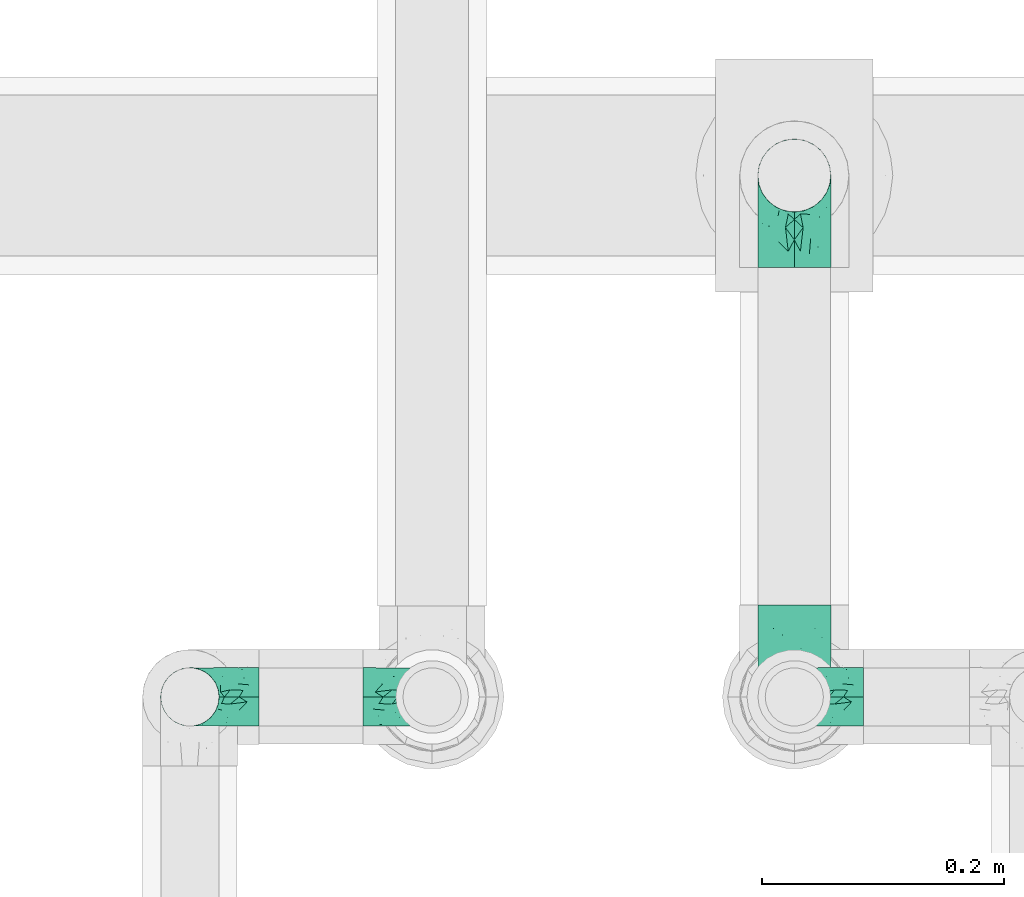
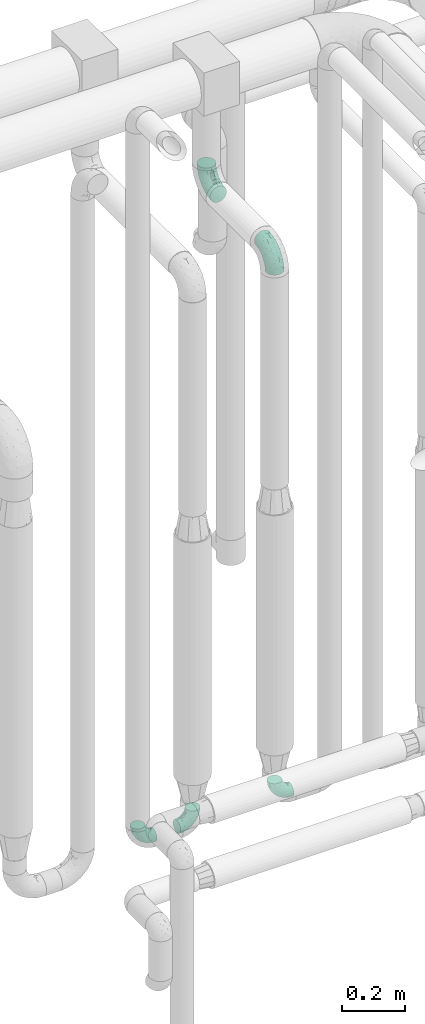
# One storey, part 716 of 827: 5 flow fittings.
"""IFC2X3 building model written with IfcOpenShell, lengths in millimetres."""

from ifc_helpers import new_model, entity, si_unit, converted_unit, derived_unit, direction, frame, origin, place, context, subcontext, project, spatial, faceted_brep, source, transform, mapped, material, type_object, type_shapes, element, save


model = new_model("IFC2X3")

# Units and contexts
model_context = context("Model", 3, precision=0.01, world=origin(), true_north=direction((6.12303176911189e-17, 1.0)))
body_context = subcontext(model_context, "Body", "Model", "MODEL_VIEW")
ifc_project = project(units=[si_unit("LENGTHUNIT", "METRE", prefix="MILLI"), si_unit("AREAUNIT", "SQUARE_METRE"), si_unit("VOLUMEUNIT", "CUBIC_METRE"), converted_unit("PLANEANGLEUNIT", "DEGREE", entity("IfcRatioMeasure", 0.0174532925199433), si_unit("PLANEANGLEUNIT", "RADIAN"), dimensions=[0, 0, 0, 0, 0, 0, 0]), si_unit("MASSUNIT", "GRAM", prefix="KILO"), derived_unit("MASSDENSITYUNIT", [(si_unit("MASSUNIT", "GRAM", prefix="KILO"), 1), (si_unit("LENGTHUNIT", "METRE"), -3)]), derived_unit("MOMENTOFINERTIAUNIT", [(si_unit("LENGTHUNIT", "METRE"), 4)]), si_unit("TIMEUNIT", "SECOND"), si_unit("FREQUENCYUNIT", "HERTZ"), si_unit("THERMODYNAMICTEMPERATUREUNIT", "DEGREE_CELSIUS"), derived_unit("THERMALTRANSMITTANCEUNIT", [(si_unit("MASSUNIT", "GRAM", prefix="KILO"), 1), (si_unit("THERMODYNAMICTEMPERATUREUNIT", "KELVIN"), -1), (si_unit("TIMEUNIT", "SECOND"), -3)]), derived_unit("VOLUMETRICFLOWRATEUNIT", [(si_unit("LENGTHUNIT", "METRE"), 3), (si_unit("TIMEUNIT", "SECOND"), -1)]), derived_unit("MASSFLOWRATEUNIT", [(si_unit("MASSUNIT", "GRAM", prefix="KILO"), 1), (si_unit("TIMEUNIT", "SECOND"), -1)]), derived_unit("ROTATIONALFREQUENCYUNIT", [(si_unit("TIMEUNIT", "SECOND"), -1)]), si_unit("ELECTRICCURRENTUNIT", "AMPERE"), si_unit("ELECTRICVOLTAGEUNIT", "VOLT"), si_unit("POWERUNIT", "WATT"), si_unit("FORCEUNIT", "NEWTON", prefix="KILO"), si_unit("ILLUMINANCEUNIT", "LUX"), si_unit("LUMINOUSFLUXUNIT", "LUMEN"), si_unit("LUMINOUSINTENSITYUNIT", "CANDELA"), derived_unit("USERDEFINED", [(si_unit("MASSUNIT", "GRAM", prefix="KILO"), -1), (si_unit("LENGTHUNIT", "METRE"), -2), (si_unit("TIMEUNIT", "SECOND"), 3), (si_unit("LUMINOUSFLUXUNIT", "LUMEN"), 1)]), derived_unit("LINEARVELOCITYUNIT", [(si_unit("LENGTHUNIT", "METRE"), 1), (si_unit("TIMEUNIT", "SECOND"), -1)]), si_unit("PRESSUREUNIT", "PASCAL"), derived_unit("USERDEFINED", [(si_unit("LENGTHUNIT", "METRE"), -2), (si_unit("MASSUNIT", "GRAM", prefix="KILO"), 1), (si_unit("TIMEUNIT", "SECOND"), -2)]), derived_unit("LINEARFORCEUNIT", [(si_unit("MASSUNIT", "GRAM", prefix="KILO"), 1), (si_unit("LENGTHUNIT", "METRE"), 1), (si_unit("TIMEUNIT", "SECOND"), -2), (si_unit("LENGTHUNIT", "METRE"), -1)]), derived_unit("PLANARFORCEUNIT", [(si_unit("MASSUNIT", "GRAM", prefix="KILO"), 1), (si_unit("LENGTHUNIT", "METRE"), 1), (si_unit("TIMEUNIT", "SECOND"), -2), (si_unit("LENGTHUNIT", "METRE"), -2)])], contexts=[model_context])

# Site, building, storey
site_placement = place(None, origin())
site = spatial("IfcSite", under=ifc_project, at=site_placement, CompositionType="ELEMENT")
building_placement = place(site_placement, origin())
building = spatial("IfcBuilding", under=site, at=building_placement, CompositionType="ELEMENT")
storey_placement = place(building_placement, frame((0.0, 0.0, 28200.0)))
storey = spatial("IfcBuildingStorey", under=building, at=storey_placement, Name="08", CompositionType="ELEMENT", Elevation=28200.0)

# Flow fittings
ifc_material = material()
pipe_fitting_type_1 = type_object("IfcPipeFittingType", Name="ADSK_1", PredefinedType="NOTDEFINED", material=ifc_material)
shared_shape_1 = source(origin(), body_context, "Body", "Brep", [
    faceted_brep([(-57.0, 12.07, -20.91), (-57.0, 6.25, -23.33), (-57.0, 0.0, -24.15), (-57.0, -6.25, -23.33), (-57.0, -12.08, -20.91), (-57.0, -17.08, -17.08), (-57.0, -20.91, -12.08), (-57.0, -23.33, -6.25), (-57.0, -24.15, 0.0), (-57.0, -23.33, 6.25), (-57.0, -20.91, 12.07), (-57.0, -17.08, 17.08), (-57.0, -12.08, 20.91), (-57.0, -6.25, 23.33), (-57.0, 0.0, 24.15), (-57.0, 6.25, 23.33), (-57.0, 12.07, 20.91), (-57.0, 17.08, 17.08), (-57.0, 20.91, 12.07), (-57.0, 23.33, 6.25), (-57.0, 24.15, 0.0), (-57.0, 23.33, -6.25), (-57.0, 20.91, -12.08), (-57.0, 17.08, -17.08), (0.0, 57.0, -24.15), (-6.25, 57.0, -23.33), (-12.07, 57.0, -20.91), (-17.08, 57.0, -17.08), (-20.91, 57.0, -12.08), (-23.33, 57.0, -6.25), (-24.15, 57.0, 0.0), (-23.33, 57.0, 6.25), (-20.91, 57.0, 12.07), (-17.08, 57.0, 17.08), (-12.07, 57.0, 20.91), (-6.25, 57.0, 23.33), (0.0, 57.0, 24.15), (6.25, 57.0, 23.33), (12.08, 57.0, 20.91), (17.08, 57.0, 17.08), (20.91, 57.0, 12.07), (23.33, 57.0, 6.25), (24.15, 57.0, 0.0), (23.33, 57.0, -6.25), (20.91, 57.0, -12.08), (17.08, 57.0, -17.08), (12.08, 57.0, -20.91), (6.25, 57.0, -23.33), (14.9, 21.14, 6.17), (13.61, 24.64, 12.48), (6.23, 8.95, 8.98), (-41.47, -21.06, 0.0), (-41.92, -18.38, 13.72), (-24.64, -13.61, 12.48), (-37.37, -13.24, 18.15), (-6.8, -4.93, 8.18), (-21.76, -15.19, 6.22), (-12.78, -9.18, 0.0), (-37.73, -20.51, 7.75), (-7.38, 7.38, 20.24), (-23.37, -4.26, 20.42), (-11.9, -3.19, 15.86), (-42.14, -8.7, 21.82), (13.24, 37.37, 18.15), (9.33, 23.53, 16.85), (4.26, 23.37, 20.42), (2.77, 10.92, 15.55), (-29.46, 0.91, 23.52), (-44.13, 20.56, 15.69), (-39.25, 26.33, 10.88), (-49.02, 22.92, 9.96), (-34.58, 23.87, 17.15), (-15.8, 6.8, 22.81), (-8.67, 20.47, 23.88), (-18.12, 12.9, 24.08), (-48.29, 14.92, 19.65), (-44.06, -2.85, 23.78), (-9.23, 48.95, 22.58), (-3.78, 42.74, 24.07), (-40.34, 4.26, 24.09), (-44.02, 26.14, 5.46), (-44.04, 9.88, 22.74), (-4.95, 16.87, 22.52), (-2.75, 1.43, 12.5), (-25.48, 40.98, 10.71), (20.51, 37.73, 7.75), (18.38, 41.92, 13.72), (8.7, 42.14, 21.82), (-25.95, -17.97, 0.0), (2.85, 44.06, 23.78), (21.06, 41.47, 0.0), (17.97, 25.95, 0.0), (-24.04, -9.27, 17.13), (-33.26, 33.26, 5.86), (-28.55, 40.57, 0.0), (-40.57, 28.55, 0.0), (-25.29, 47.19, 4.06), (-27.01, 31.1, 16.77), (-15.7, 43.95, 19.9), (-20.27, 45.22, 15.61), (-30.53, 31.98, 12.64), (-11.28, 38.33, 22.92), (-9.97, 27.88, 24.09), (-20.15, 30.26, 21.25), (-31.25, 11.75, 23.64), (-28.75, 7.23, 24.15), (-29.53, 18.06, 22.27), (-28.44, 24.21, 20.02), (-37.55, 17.7, 20.26), (-15.88, 29.25, 22.99), (-20.82, 20.82, 23.44), (-0.91, 29.46, 23.52), (-13.5, -7.67, 12.04), (1.49, 1.56, 5.16), (8.86, 10.35, 4.59), (0.38, -0.38, 0.0), (9.18, 12.78, 0.0), (-37.37, -13.24, -18.15), (8.86, 10.35, -4.59), (-45.22, 20.27, -15.61), (-43.95, 15.7, -19.9), (-38.33, 11.28, -22.92), (-48.95, 9.23, -22.58), (-47.19, 25.29, -4.06), (-33.26, 33.26, -5.86), (18.38, 41.92, -13.72), (-30.26, 20.15, -21.25), (2.85, 44.06, -23.78), (-4.26, 40.34, -24.09), (-40.98, 25.48, -10.71), (-41.92, -18.38, -13.72), (9.25, 23.5, -16.92), (4.26, 23.37, -20.42), (13.24, 37.37, -18.15), (-37.73, -20.51, -7.75), (-11.75, 31.25, -23.64), (-7.23, 28.75, -24.15), (-12.9, 18.12, -24.08), (8.7, 42.14, -21.82), (-44.06, -2.85, -23.78), (-6.8, 15.8, -22.81), (-20.47, 8.67, -23.88), (-24.64, -13.61, -12.48), (-42.74, 3.78, -24.07), (-18.06, 29.53, -22.27), (-24.21, 28.44, -20.02), (-27.88, 9.97, -24.09), (-31.1, 27.01, -16.77), (-26.14, 44.02, -5.46), (14.9, 21.14, -6.17), (20.51, 37.73, -7.75), (-9.88, 44.04, -22.74), (-20.56, 44.13, -15.69), (-21.76, -15.19, -6.22), (-13.5, -7.67, -12.04), (-24.14, -9.76, -16.74), (-11.9, -3.19, -15.86), (-14.92, 48.29, -19.65), (-23.37, -4.26, -20.42), (-0.91, 29.46, -23.52), (-26.33, 39.25, -10.88), (-23.87, 34.58, -17.15), (-42.14, -8.7, -21.82), (-22.92, 49.02, -9.96), (13.61, 24.64, -12.48), (-31.98, 30.53, -12.64), (-16.87, 4.95, -22.52), (-17.7, 37.55, -20.26), (-29.25, 15.88, -22.99), (-20.82, 20.82, -23.44), (-29.46, 0.91, -23.52), (-7.38, 7.38, -20.24), (2.77, 10.92, -15.55), (6.23, 8.95, -8.98), (-6.8, -4.93, -8.18), (-2.81, 1.41, -12.54), (1.49, 1.56, -5.16)], [[[0, 1, 2, 3, 4, 5, 6, 7, 8, 9, 10, 11, 12, 13, 14, 15, 16, 17, 18, 19, 20, 21, 22, 23]], [[24, 25, 26, 27, 28, 29, 30, 31, 32, 33, 34, 35, 36, 37, 38, 39, 40, 41, 42, 43, 44, 45, 46, 47]], [[48, 49, 50]], [[9, 8, 51]], [[52, 53, 54]], [[55, 56, 57]], [[10, 58, 52]], [[9, 58, 10]], [[59, 60, 61]], [[54, 12, 11]], [[54, 62, 12]], [[63, 39, 38]], [[64, 65, 66]], [[62, 60, 67]], [[68, 69, 70]], [[71, 69, 68]], [[72, 73, 74]], [[16, 75, 17]], [[13, 76, 14]], [[35, 77, 78]], [[14, 79, 15]], [[17, 68, 18]], [[14, 76, 79]], [[20, 19, 80]], [[70, 19, 18]], [[81, 15, 79]], [[15, 81, 16]], [[73, 72, 82]], [[66, 83, 50]], [[32, 31, 84]], [[85, 86, 49]], [[63, 87, 65]], [[56, 58, 88]], [[36, 89, 37]], [[85, 41, 40]], [[36, 35, 78]], [[90, 41, 85]], [[40, 39, 86]], [[12, 62, 13]], [[86, 85, 40]], [[48, 85, 49]], [[85, 91, 90]], [[87, 38, 37]], [[92, 60, 54]], [[80, 69, 93]], [[93, 94, 95]], [[10, 52, 11]], [[94, 96, 30]], [[97, 98, 99]], [[80, 93, 95]], [[100, 97, 84]], [[99, 98, 33]], [[101, 102, 78]], [[103, 101, 98]], [[96, 31, 30]], [[77, 98, 101]], [[77, 35, 34]], [[34, 33, 98]], [[9, 51, 58]], [[87, 63, 38]], [[104, 105, 74]], [[106, 103, 107]], [[106, 81, 104]], [[75, 68, 17]], [[108, 107, 71]], [[33, 32, 99]], [[109, 103, 110]], [[101, 109, 102]], [[89, 78, 111]], [[53, 52, 58]], [[54, 11, 52]], [[60, 62, 54]], [[88, 58, 51]], [[76, 62, 67]], [[53, 112, 92]], [[60, 59, 72]], [[39, 63, 86]], [[49, 86, 63]], [[89, 87, 37]], [[42, 41, 90]], [[111, 82, 65]], [[111, 65, 87]], [[65, 59, 66]], [[104, 81, 79]], [[75, 81, 108]], [[32, 84, 99]], [[97, 99, 84]], [[98, 97, 103]], [[106, 107, 108]], [[74, 102, 110]], [[111, 78, 102]], [[74, 110, 104]], [[74, 67, 72]], [[61, 92, 112]], [[66, 59, 61]], [[56, 53, 58]], [[66, 50, 49]], [[61, 112, 83]], [[66, 49, 64]], [[78, 89, 36]], [[87, 89, 111]], [[62, 76, 13]], [[79, 76, 67]], [[100, 93, 69]], [[96, 93, 84]], [[55, 113, 50]], [[113, 114, 50]], [[104, 79, 105]], [[106, 104, 110]], [[20, 80, 95]], [[85, 48, 91]], [[115, 114, 113]], [[116, 91, 48]], [[70, 80, 19]], [[93, 96, 94]], [[84, 31, 96]], [[103, 106, 110]], [[81, 106, 108]], [[103, 97, 107]], [[71, 107, 97]], [[71, 97, 100]], [[108, 71, 68]], [[79, 67, 105]], [[67, 74, 105]], [[115, 113, 57]], [[112, 56, 55]], [[56, 88, 57]], [[60, 72, 67]], [[82, 72, 59]], [[65, 82, 59]], [[82, 111, 73]], [[111, 102, 73]], [[102, 74, 73]], [[81, 75, 16]], [[68, 75, 108]], [[68, 70, 18]], [[80, 70, 69]], [[98, 77, 34]], [[78, 77, 101]], [[93, 100, 84]], [[71, 100, 69]], [[102, 109, 110]], [[101, 103, 109]], [[53, 92, 54]], [[61, 60, 92]], [[56, 112, 53]], [[83, 112, 55]], [[50, 83, 55]], [[61, 83, 66]], [[49, 63, 64]], [[65, 64, 63]], [[57, 113, 55]], [[114, 115, 116]], [[116, 48, 114]], [[48, 50, 114]], [[117, 5, 4]], [[116, 115, 118]], [[119, 120, 23]], [[121, 122, 120]], [[95, 123, 20]], [[0, 23, 120]], [[124, 95, 94]], [[125, 45, 44]], [[121, 120, 126]], [[24, 127, 128]], [[22, 21, 129]], [[0, 122, 1]], [[5, 117, 130]], [[131, 132, 133]], [[134, 88, 51]], [[135, 136, 137]], [[6, 5, 130]], [[46, 138, 47]], [[139, 3, 2]], [[140, 141, 137]], [[6, 134, 7]], [[134, 130, 142]], [[143, 2, 1]], [[144, 126, 145]], [[121, 146, 143]], [[147, 120, 119]], [[94, 148, 124]], [[149, 150, 91]], [[30, 29, 148]], [[151, 25, 128]], [[27, 152, 28]], [[134, 153, 88]], [[154, 155, 156]], [[27, 26, 157]], [[151, 26, 25]], [[155, 158, 156]], [[24, 47, 127]], [[1, 122, 143]], [[138, 132, 159]], [[160, 152, 161]], [[24, 128, 25]], [[46, 133, 138]], [[162, 117, 4]], [[148, 160, 124]], [[152, 160, 163]], [[154, 142, 155]], [[45, 125, 133]], [[133, 46, 45]], [[125, 164, 133]], [[51, 7, 134]], [[42, 90, 43]], [[165, 147, 129]], [[153, 134, 142]], [[43, 150, 44]], [[162, 4, 3]], [[141, 140, 166]], [[117, 162, 158]], [[163, 29, 28]], [[43, 90, 150]], [[123, 21, 20]], [[144, 151, 135]], [[157, 152, 27]], [[167, 145, 161]], [[23, 22, 119]], [[168, 126, 169]], [[121, 168, 146]], [[139, 143, 170]], [[142, 130, 117]], [[8, 7, 51]], [[134, 6, 130]], [[139, 162, 3]], [[170, 166, 158]], [[170, 158, 162]], [[158, 171, 156]], [[44, 150, 125]], [[91, 150, 90]], [[164, 125, 150]], [[132, 138, 133]], [[127, 138, 159]], [[131, 164, 172]], [[132, 171, 140]], [[135, 151, 128]], [[157, 151, 167]], [[22, 129, 119]], [[147, 119, 129]], [[120, 147, 126]], [[144, 145, 167]], [[137, 146, 169]], [[170, 143, 146]], [[137, 169, 135]], [[137, 159, 140]], [[171, 172, 156]], [[173, 174, 175]], [[156, 175, 154]], [[174, 57, 153]], [[132, 172, 171]], [[172, 164, 173]], [[143, 139, 2]], [[162, 139, 170]], [[138, 127, 47]], [[128, 127, 159]], [[165, 124, 160]], [[123, 124, 129]], [[149, 173, 164]], [[176, 174, 173]], [[135, 128, 136]], [[144, 135, 169]], [[150, 149, 164]], [[176, 118, 115]], [[149, 91, 116]], [[30, 148, 94]], [[163, 148, 29]], [[124, 123, 95]], [[129, 21, 123]], [[126, 144, 169]], [[151, 144, 167]], [[126, 147, 145]], [[161, 145, 147]], [[161, 147, 165]], [[167, 161, 152]], [[128, 159, 136]], [[159, 137, 136]], [[154, 153, 142]], [[132, 140, 159]], [[174, 176, 57]], [[57, 88, 153]], [[166, 140, 171]], [[158, 166, 171]], [[166, 170, 141]], [[170, 146, 141]], [[146, 137, 141]], [[151, 157, 26]], [[152, 157, 167]], [[152, 163, 28]], [[148, 163, 160]], [[120, 122, 0]], [[143, 122, 121]], [[124, 165, 129]], [[161, 165, 160]], [[146, 168, 169]], [[121, 126, 168]], [[142, 117, 155]], [[158, 155, 117]], [[175, 156, 172]], [[153, 154, 174]], [[173, 175, 172]], [[174, 154, 175]], [[164, 131, 133]], [[172, 132, 131]], [[176, 173, 118]], [[57, 176, 115]], [[173, 149, 118]], [[149, 116, 118]]]),
])
type_shapes(pipe_fitting_type_1, [shared_shape_1])
for number, where, z_axis, x_axis, name in (
    (1, (59098.13, 17500.0, 400.0), (0.0, -1.0, 0.0), (0.0, 0.0, -1.0), "ADSK_1"),
    (2, (59298.13, 17500.0, 400.0), (0.0, -1.0, 0.0), (1.0, 0.0, 0.0), "ADSK_1"),
    (3, (59596.67, 17500.0, 400.0), (0.0, 1.0, 0.0), (-1.0, 0.0, 0.0), "ADSK_1"),
):
    element("IfcFlowFitting", number, at=place(storey_placement, frame(where, z_axis=z_axis, x_axis=x_axis)), inside=storey, type_object=pipe_fitting_type_1, material=ifc_material, Name=name, ObjectType="ADSK_1", context=body_context, shape_type="MappedRepresentation", body=[
        mapped(shared_shape_1, transform((0.0, 0.0, 0.0), scale=1.0)),
    ])
pipe_fitting_type_2 = type_object("IfcPipeFittingType", Name="ADSK_1", PredefinedType="NOTDEFINED", material=ifc_material)
shared_shape_2 = source(origin(), body_context, "Body", "Brep", [
    faceted_brep([(-76.0, 15.07, -26.11), (-76.0, 7.8, -29.12), (-76.0, 0.0, -30.15), (-76.0, -7.8, -29.12), (-76.0, -15.08, -26.11), (-76.0, -21.32, -21.32), (-76.0, -26.11, -15.08), (-76.0, -29.12, -7.8), (-76.0, -30.15, 0.0), (-76.0, -29.12, 7.8), (-76.0, -26.11, 15.07), (-76.0, -21.32, 21.32), (-76.0, -15.08, 26.11), (-76.0, -7.8, 29.12), (-76.0, 0.0, 30.15), (-76.0, 7.8, 29.12), (-76.0, 15.07, 26.11), (-76.0, 21.32, 21.32), (-76.0, 26.11, 15.07), (-76.0, 29.12, 7.8), (-76.0, 30.15, 0.0), (-76.0, 29.12, -7.8), (-76.0, 26.11, -15.08), (-76.0, 21.32, -21.32), (0.0, 76.0, -30.15), (-7.8, 76.0, -29.12), (-15.07, 76.0, -26.11), (-21.32, 76.0, -21.32), (-26.11, 76.0, -15.08), (-29.12, 76.0, -7.8), (-30.15, 76.0, 0.0), (-29.12, 76.0, 7.8), (-26.11, 76.0, 15.07), (-21.32, 76.0, 21.32), (-15.07, 76.0, 26.11), (-7.8, 76.0, 29.12), (0.0, 76.0, 30.15), (7.8, 76.0, 29.12), (15.08, 76.0, 26.11), (21.32, 76.0, 21.32), (26.11, 76.0, 15.07), (29.12, 76.0, 7.8), (30.15, 76.0, 0.0), (29.12, 76.0, -7.8), (26.11, 76.0, -15.08), (21.32, 76.0, -21.32), (15.08, 76.0, -26.11), (7.8, 76.0, -29.12), (10.79, 31.43, 21.07), (4.32, 31.7, 25.72), (1.65, 15.19, 19.92), (-61.17, -27.8, 0.0), (-51.1, -25.49, 9.84), (-56.14, -10.61, 27.27), (-31.7, -4.32, 25.72), (-39.75, 1.72, 29.41), (-43.2, -24.95, 0.0), (-1.86, 1.86, 0.0), (4.49, 7.65, 5.78), (-7.82, -4.61, 5.83), (-56.21, -22.79, 17.21), (-58.98, -3.38, 29.7), (-53.96, 5.6, 30.07), (-10.86, 10.86, 25.48), (-17.2, -2.6, 20.44), (-49.15, -16.01, 22.7), (-22.18, -14.24, 7.99), (-28.4, -17.42, 0.0), (-13.61, -9.88, 0.0), (-39.0, 23.48, 27.76), (-58.76, 12.54, 28.36), (-41.61, 15.41, 29.48), (16.01, 49.15, 22.7), (-58.55, 25.93, 19.53), (-51.53, 33.5, 13.51), (-64.92, 28.76, 12.4), (-7.48, 23.14, 28.25), (-1.72, 39.75, 29.41), (-12.04, 27.88, 29.88), (-63.91, 18.81, 24.52), (-11.63, 65.16, 28.18), (-4.97, 57.02, 30.05), (9.88, 13.61, 0.0), (-62.5, 31.74, 5.02), (-45.17, 30.98, 21.2), (-21.78, 9.76, 28.58), (10.61, 56.14, 27.27), (-32.09, 54.42, 13.26), (22.79, 56.21, 17.21), (15.38, 31.17, 15.63), (25.49, 51.1, 9.84), (21.84, 36.35, 5.92), (24.95, 43.2, 0.0), (3.38, 58.98, 29.7), (-31.17, -15.38, 15.63), (-39.39, 41.78, 15.45), (-34.56, 41.13, 20.79), (-39.81, -23.25, 5.49), (27.8, 61.17, 0.0), (-31.74, 62.5, 5.02), (-53.07, 36.29, 0.0), (-42.95, 42.95, 7.29), (-36.29, 53.07, 0.0), (-19.83, 58.51, 24.79), (-25.48, 60.2, 19.41), (-14.53, 50.96, 28.57), (-13.31, 37.09, 30.07), (-26.16, 40.06, 26.4), (-32.43, -10.35, 21.9), (17.42, 28.4, 0.0), (14.24, 22.18, 7.99), (-38.67, 9.72, 30.15), (-24.66, 17.36, 30.09), (-37.08, 31.49, 24.99), (-49.27, 22.83, 25.24), (-20.8, 38.81, 28.63), (-27.58, 27.58, 29.2), (-36.07, -20.23, 10.71), (-15.19, -6.16, 14.9), (6.6, 15.4, 14.49), (-2.51, 2.51, 11.35), (-65.16, 11.63, -28.18), (-49.15, -16.01, -22.7), (-57.02, 4.97, -30.05), (-25.93, 58.55, -19.53), (-33.5, 51.53, -13.51), (-28.76, 64.92, -12.4), (-60.2, 25.48, -19.41), (-58.51, 19.83, -24.79), (4.61, 7.82, -5.83), (-7.65, -4.49, -5.78), (-2.51, 2.51, -11.35), (-62.5, 31.74, -5.02), (-50.96, 14.53, -28.57), (-37.09, 13.31, -30.07), (-42.95, 42.95, -7.29), (25.49, 51.1, -9.84), (22.79, 56.21, -17.21), (-40.06, 26.16, -26.4), (3.38, 58.98, -29.7), (-5.6, 53.96, -30.07), (-27.88, 12.04, -29.88), (-9.76, 21.78, -28.58), (-23.14, 7.48, -28.25), (-51.1, -25.49, -9.84), (15.38, 31.17, -15.63), (16.01, 49.15, -22.7), (-23.48, 39.0, -27.76), (-12.54, 58.76, -28.36), (-15.41, 41.61, -29.48), (-56.21, -22.79, -17.21), (-9.72, 38.67, -30.15), (-17.36, 24.66, -30.09), (-22.18, -14.24, -7.99), (-41.13, 34.56, -20.79), (-31.74, 62.5, -5.02), (-58.98, -3.38, -29.7), (-31.17, -15.38, -15.63), (-56.14, -10.61, -27.27), (14.24, 22.18, -7.99), (23.25, 39.81, -5.49), (-31.49, 37.08, -24.99), (-15.19, -6.16, -14.9), (1.65, 15.19, -19.92), (-18.81, 63.91, -24.52), (-32.59, -11.62, -20.84), (-31.7, -4.32, -25.72), (-17.2, -2.6, -20.44), (-39.75, 1.72, -29.41), (-54.42, 32.09, -13.26), (-30.98, 45.17, -21.2), (10.61, 56.14, -27.27), (10.23, 31.31, -21.52), (4.32, 31.7, -25.72), (-41.78, 39.39, -15.45), (-1.72, 39.75, -29.41), (-36.35, -21.84, -5.92), (-22.83, 49.27, -25.24), (-38.81, 20.8, -28.63), (-27.58, 27.58, -29.2), (-10.86, 10.86, -25.48), (20.23, 36.07, -10.71), (6.6, 15.4, -14.49)], [[[0, 1, 2, 3, 4, 5, 6, 7, 8, 9, 10, 11, 12, 13, 14, 15, 16, 17, 18, 19, 20, 21, 22, 23]], [[24, 25, 26, 27, 28, 29, 30, 31, 32, 33, 34, 35, 36, 37, 38, 39, 40, 41, 42, 43, 44, 45, 46, 47]], [[48, 49, 50]], [[51, 52, 9]], [[53, 54, 55]], [[9, 52, 10]], [[56, 52, 51]], [[57, 58, 59]], [[11, 10, 60]], [[14, 61, 62]], [[63, 54, 64]], [[65, 12, 11]], [[65, 53, 12]], [[66, 67, 68]], [[69, 70, 71]], [[72, 39, 38]], [[73, 74, 75]], [[15, 70, 16]], [[76, 77, 78]], [[16, 79, 17]], [[13, 61, 14]], [[35, 80, 81]], [[14, 62, 15]], [[17, 73, 18]], [[57, 82, 58]], [[20, 19, 83]], [[75, 19, 18]], [[70, 15, 62]], [[73, 84, 74]], [[78, 85, 76]], [[38, 86, 72]], [[32, 31, 87]], [[88, 89, 90]], [[91, 92, 90]], [[72, 86, 49]], [[36, 93, 37]], [[75, 83, 19]], [[36, 35, 81]], [[60, 94, 65]], [[40, 90, 41]], [[95, 96, 87]], [[88, 90, 40]], [[66, 97, 67]], [[90, 98, 41]], [[40, 39, 88]], [[99, 31, 30]], [[20, 83, 100]], [[101, 102, 100]], [[52, 60, 10]], [[102, 99, 30]], [[96, 103, 104]], [[83, 101, 100]], [[12, 53, 13]], [[104, 103, 33]], [[105, 106, 81]], [[107, 105, 103]], [[64, 54, 108]], [[80, 103, 105]], [[80, 35, 34]], [[34, 33, 103]], [[86, 38, 37]], [[109, 110, 82]], [[71, 111, 112]], [[69, 107, 113]], [[79, 73, 17]], [[114, 113, 84]], [[33, 32, 104]], [[115, 107, 116]], [[105, 115, 106]], [[93, 81, 77]], [[54, 53, 65]], [[61, 53, 55]], [[108, 94, 64]], [[54, 63, 85]], [[93, 86, 37]], [[77, 76, 49]], [[77, 49, 86]], [[49, 63, 50]], [[60, 52, 117]], [[65, 11, 60]], [[39, 72, 88]], [[89, 88, 72]], [[71, 70, 62]], [[79, 70, 114]], [[103, 96, 107]], [[69, 113, 114]], [[112, 106, 116]], [[77, 81, 106]], [[112, 116, 71]], [[112, 55, 85]], [[64, 50, 63]], [[57, 59, 68]], [[32, 87, 104]], [[96, 104, 87]], [[94, 118, 64]], [[50, 119, 89]], [[50, 64, 118]], [[50, 89, 48]], [[81, 93, 36]], [[86, 93, 77]], [[53, 61, 13]], [[62, 61, 55]], [[71, 62, 111]], [[69, 71, 116]], [[95, 101, 74]], [[99, 101, 87]], [[118, 66, 59]], [[117, 97, 66]], [[117, 66, 94]], [[91, 89, 110]], [[91, 110, 109]], [[110, 89, 119]], [[9, 8, 51]], [[98, 90, 92]], [[98, 42, 41]], [[101, 83, 74]], [[101, 99, 102]], [[87, 31, 99]], [[62, 55, 111]], [[55, 112, 111]], [[107, 69, 116]], [[70, 69, 114]], [[107, 96, 113]], [[84, 113, 96]], [[84, 96, 95]], [[114, 84, 73]], [[70, 79, 16]], [[73, 79, 114]], [[54, 85, 55]], [[76, 85, 63]], [[49, 76, 63]], [[77, 106, 78]], [[106, 112, 78]], [[85, 78, 112]], [[73, 75, 18]], [[83, 75, 74]], [[103, 80, 34]], [[81, 80, 105]], [[101, 95, 87]], [[84, 95, 74]], [[106, 115, 116]], [[105, 107, 115]], [[120, 59, 58]], [[82, 110, 58]], [[119, 58, 110]], [[118, 59, 120]], [[66, 68, 59]], [[54, 65, 108]], [[94, 108, 65]], [[66, 118, 94]], [[50, 118, 120]], [[50, 120, 119]], [[119, 120, 58]], [[89, 72, 48]], [[49, 48, 72]], [[60, 117, 94]], [[117, 52, 97]], [[52, 56, 97]], [[67, 97, 56]], [[92, 91, 109]], [[89, 91, 90]], [[121, 1, 0]], [[122, 5, 4]], [[2, 1, 123]], [[124, 125, 126]], [[127, 128, 23]], [[129, 130, 131]], [[100, 132, 20]], [[133, 134, 123]], [[135, 100, 102]], [[136, 137, 44]], [[133, 128, 138]], [[24, 139, 140]], [[141, 142, 143]], [[121, 128, 133]], [[6, 144, 7]], [[137, 145, 146]], [[144, 51, 7]], [[147, 148, 149]], [[144, 6, 150]], [[149, 151, 152]], [[153, 68, 67]], [[154, 128, 127]], [[30, 155, 102]], [[43, 42, 98]], [[156, 3, 2]], [[157, 144, 150]], [[158, 4, 3]], [[24, 140, 25]], [[155, 135, 102]], [[159, 160, 109]], [[30, 29, 155]], [[147, 138, 161]], [[27, 124, 28]], [[57, 129, 82]], [[162, 163, 131]], [[27, 26, 164]], [[148, 26, 25]], [[165, 166, 167]], [[24, 47, 139]], [[143, 168, 141]], [[22, 21, 169]], [[125, 124, 170]], [[148, 25, 140]], [[46, 146, 171]], [[158, 122, 4]], [[0, 23, 128]], [[1, 121, 123]], [[109, 82, 159]], [[45, 44, 137]], [[146, 46, 45]], [[136, 43, 98]], [[132, 21, 20]], [[136, 98, 92]], [[172, 173, 146]], [[46, 171, 47]], [[43, 136, 44]], [[174, 154, 169]], [[171, 173, 175]], [[6, 5, 150]], [[126, 29, 28]], [[176, 56, 144]], [[122, 158, 166]], [[164, 124, 27]], [[177, 161, 170]], [[23, 22, 127]], [[178, 138, 179]], [[133, 178, 134]], [[156, 123, 168]], [[156, 158, 3]], [[168, 143, 166]], [[168, 166, 158]], [[166, 180, 167]], [[173, 171, 146]], [[139, 171, 175]], [[172, 145, 163]], [[173, 180, 142]], [[5, 122, 150]], [[157, 150, 122]], [[137, 136, 181]], [[146, 45, 137]], [[149, 148, 140]], [[164, 148, 177]], [[128, 154, 138]], [[147, 161, 177]], [[152, 134, 179]], [[168, 123, 134]], [[152, 179, 149]], [[152, 175, 142]], [[57, 130, 129]], [[157, 165, 167]], [[22, 169, 127]], [[154, 127, 169]], [[163, 167, 180]], [[162, 157, 167]], [[173, 163, 180]], [[182, 163, 145]], [[123, 156, 2]], [[158, 156, 168]], [[171, 139, 47]], [[140, 139, 175]], [[149, 140, 151]], [[147, 149, 179]], [[174, 135, 125]], [[132, 135, 169]], [[176, 157, 153]], [[176, 153, 67]], [[153, 157, 162]], [[182, 159, 129]], [[181, 160, 159]], [[181, 159, 145]], [[51, 144, 56]], [[51, 8, 7]], [[135, 132, 100]], [[169, 21, 132]], [[126, 155, 29]], [[135, 155, 125]], [[140, 175, 151]], [[175, 152, 151]], [[138, 147, 179]], [[148, 147, 177]], [[138, 154, 161]], [[170, 161, 154]], [[170, 154, 174]], [[177, 170, 124]], [[148, 164, 26]], [[124, 164, 177]], [[173, 142, 175]], [[143, 142, 180]], [[166, 143, 180]], [[168, 134, 141]], [[134, 152, 141]], [[142, 141, 152]], [[124, 126, 28]], [[155, 126, 125]], [[128, 121, 0]], [[123, 121, 133]], [[135, 174, 169]], [[170, 174, 125]], [[134, 178, 179]], [[133, 138, 178]], [[130, 153, 162]], [[68, 153, 130]], [[57, 68, 130]], [[182, 129, 131]], [[159, 82, 129]], [[157, 122, 165]], [[166, 165, 122]], [[163, 162, 167]], [[162, 131, 130]], [[145, 172, 146]], [[163, 173, 172]], [[159, 182, 145]], [[131, 163, 182]], [[56, 176, 67]], [[157, 176, 144]], [[137, 181, 145]], [[181, 136, 160]], [[136, 92, 160]], [[109, 160, 92]]]),
])
type_shapes(pipe_fitting_type_2, [shared_shape_2])
for number, where, z_axis, x_axis, name in (
    (4, (59596.67, 17930.1, 2494.74), (-1.0, 0.0, 0.0), (0.0, 0.0, -1.0), "ADSK_1"),
    (5, (59596.67, 17500.0, 2494.74), (1.0, 0.0, 0.0), (0.0, -1.0, 0.0), "ADSK_1"),
):
    element("IfcFlowFitting", number, at=place(storey_placement, frame(where, z_axis=z_axis, x_axis=x_axis)), inside=storey, type_object=pipe_fitting_type_2, material=ifc_material, Name=name, ObjectType="ADSK_1", context=body_context, shape_type="MappedRepresentation", body=[
        mapped(shared_shape_2, transform((0.0, 0.0, 0.0), scale=1.0)),
    ])

save(model, "model.ifc")
